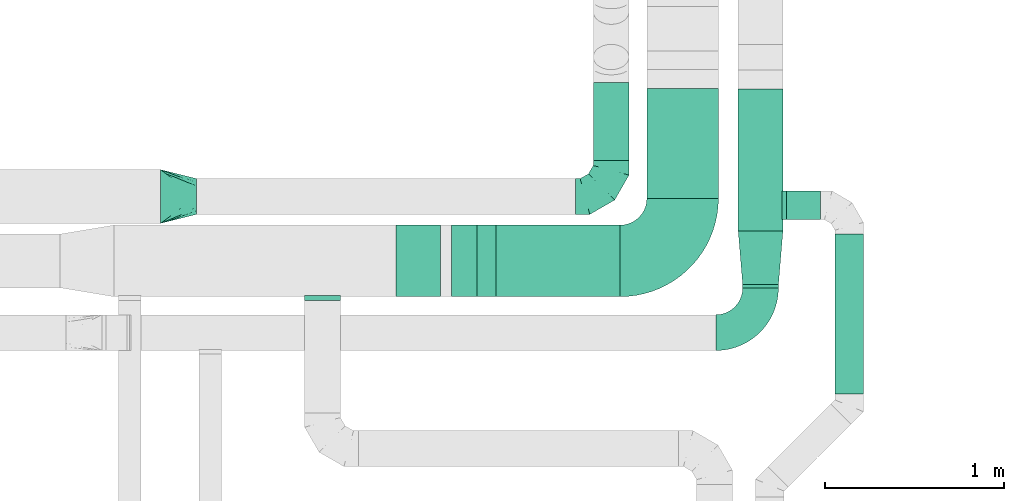
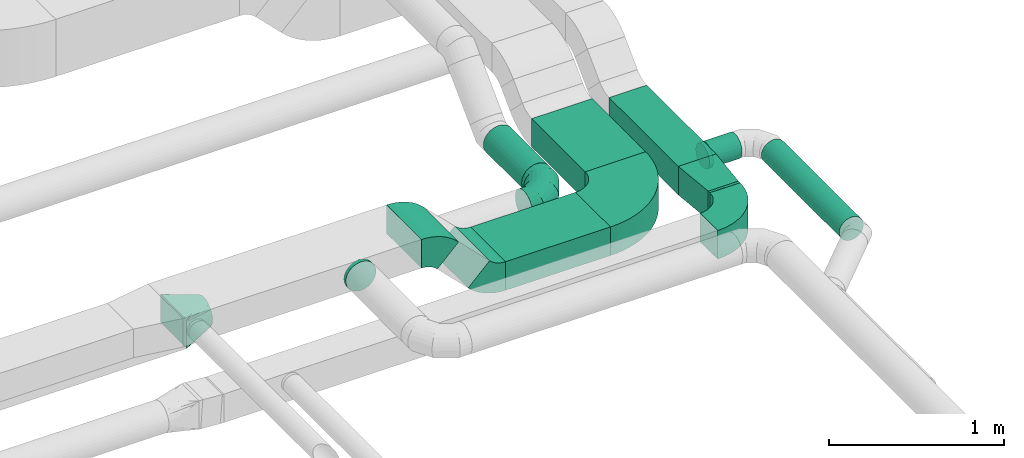
# One storey, part 27 of 60: 9 flow fittings, 7 flow segments.
"""IFC2X3 building model written with IfcOpenShell, lengths in millimetres."""

import ifcopenshell
import ifcopenshell.guid

model = None  # the IFC model being written
_history = None  # IfcOwnerHistory: only IFC2X3 demands one
_inside = {}  # id of a spatial element -> (the spatial element, [elements in it])
_under = {}  # id of a project, library or spatial element -> (it, [spatial elements below it])
_declared = {}  # id of a project -> (the project, [libraries it declares])
_typed = {}  # id of a type object -> (the type object, [elements of that type])
_made_of = {}  # id of a material, layer set ... -> (it, [elements and type objects made of it])


def new_model(schema):
    """Start an empty IFC model of exactly this schema.

    Asked for "IFC4X3", IfcOpenShell would pick the latest addendum, in which some entities
    have other attributes; the version numbers below select the first issue.
    IFC2X3 requires an IfcOwnerHistory on every rooted entity: one is made here for all.
    """
    global model, _history
    if schema == "IFC4X3":
        model = ifcopenshell.file(schema_version=(4, 3, 0, 0))
    else:
        model = ifcopenshell.file(schema=schema)
    _inside.clear()
    _under.clear()
    _declared.clear()
    _typed.clear()
    _made_of.clear()
    _history = None
    if model.schema == "IFC2X3":
        org = make("IfcOrganization", Name="unknown")
        user = make(
            "IfcPersonAndOrganization",
            ThePerson=make("IfcPerson", FamilyName="unknown"),
            TheOrganization=org,
        )
        app = make(
            "IfcApplication",
            ApplicationDeveloper=org,
            Version="unknown",
            ApplicationFullName="unknown",
            ApplicationIdentifier="unknown",
        )
        _history = make(
            "IfcOwnerHistory",
            OwningUser=user,
            OwningApplication=app,
            ChangeAction="ADDED",
            CreationDate=0,
        )
    return model


def make(cls, **values):
    """One entity of the class cls with the attributes given. An attribute that is None is left unset."""
    return model.create_entity(
        cls, **{name: value for name, value in values.items() if value is not None}
    )


def entity(cls, *values):
    """Any entity or typed value of the class cls, its attributes in the order of the schema. None: left unset."""
    e = model.create_entity(cls)
    for i, value in enumerate(values):
        if value is not None:
            e[i] = value
    return e


def rooted(cls, **values):
    """An entity with a GlobalId (a new one), such as an element, a storey or a relation."""
    return make(cls, GlobalId=ifcopenshell.guid.new(), OwnerHistory=_history, **values)


def si_unit(unit_type, name, prefix=None):
    """IfcSIUnit, for example si_unit("LENGTHUNIT", "METRE", prefix="MILLI")."""
    return make("IfcSIUnit", UnitType=unit_type, Prefix=prefix, Name=name)


def converted_unit(unit_type, name, factor, base, dimensions=None, offset=None):
    """IfcConversionBasedUnit, such as the inch: factor (a typed value) times the base unit."""
    return make(
        "IfcConversionBasedUnit"
        if offset is None
        else "IfcConversionBasedUnitWithOffset",
        ConversionOffset=offset,
        Dimensions=None
        if dimensions is None
        else entity("IfcDimensionalExponents", *dimensions),
        UnitType=unit_type,
        Name=name,
        ConversionFactor=make(
            "IfcMeasureWithUnit", ValueComponent=factor, UnitComponent=base
        ),
    )


def derived_unit(unit_type, elements):
    """IfcDerivedUnit: a product of units, each with its exponent."""
    return make(
        "IfcDerivedUnit",
        Elements=[
            make("IfcDerivedUnitElement", Unit=unit, Exponent=power)
            for unit, power in elements
        ],
        UnitType=unit_type,
    )


def assignment(units):
    """IfcUnitAssignment: the units of a project."""
    return None if units is None else make("IfcUnitAssignment", Units=units)


def point(xyz):
    """IfcCartesianPoint."""
    return None if xyz is None else make("IfcCartesianPoint", Coordinates=xyz)


def direction(xyz):
    """IfcDirection."""
    return None if xyz is None else make("IfcDirection", DirectionRatios=xyz)


def frame(location, z_axis=None, x_axis=None):
    """IfcAxis2Placement3D, a coordinate frame: its origin and axes. An axis left out is left unset."""
    return make(
        "IfcAxis2Placement3D",
        Location=point(location),
        Axis=direction(z_axis),
        RefDirection=direction(x_axis),
    )


def frame_2d(location, x_axis=None):
    """IfcAxis2Placement2D, a coordinate frame in the plane: its origin and x axis."""
    return make(
        "IfcAxis2Placement2D", Location=point(location), RefDirection=direction(x_axis)
    )


def origin():
    """The frame at (0, 0, 0) with its axes left unset."""
    return frame((0.0, 0.0, 0.0))


def origin_2d_with_axis():
    """The frame at (0, 0) in the plane with the x axis (1, 0) written out."""
    return frame_2d((0.0, 0.0), x_axis=(1.0, 0.0))


def place(relative_to, where):
    """IfcLocalPlacement: puts the frame where relative to a parent placement (None: the world)."""
    return make(
        "IfcLocalPlacement", PlacementRelTo=relative_to, RelativePlacement=where
    )


def context(
    kind, dimensions, precision=None, world=None, true_north=None, identifier=None
):
    """IfcGeometricRepresentationContext, for example the 3D "Model" context."""
    return make(
        "IfcGeometricRepresentationContext",
        ContextIdentifier=identifier,
        ContextType=kind,
        CoordinateSpaceDimension=dimensions,
        Precision=precision,
        WorldCoordinateSystem=world,
        TrueNorth=true_north,
    )


def subcontext(parent, identifier, kind, view, scale=None):
    """IfcGeometricRepresentationSubContext, for example "Body" below "Model"."""
    return make(
        "IfcGeometricRepresentationSubContext",
        ContextIdentifier=identifier,
        ContextType=kind,
        ParentContext=parent,
        TargetScale=scale,
        TargetView=view,
    )


def project(units=None, contexts=None):
    """IfcProject with its units and contexts."""
    return rooted(
        "IfcProject",
        Name="project",
        RepresentationContexts=contexts,
        UnitsInContext=assignment(units),
    )


def spatial(cls, under=None, at=None, **own):
    """A site, building, storey or space (cls), placed at a placement, below another one or the project."""
    s = rooted(cls, ObjectPlacement=at, **own)
    if under is not None:
        _under.setdefault(under.id(), (under, []))[1].append(s)
    return s


def polyline(points):
    """IfcPolyline through the points."""
    return make("IfcPolyline", Points=[point(p) for p in points])


def circle_curve(where, radius):
    """IfcCircle in the frame where."""
    return make("IfcCircle", Position=where, Radius=radius)


def parameter(value):
    """IfcParameterValue: where a trimmed curve begins or ends, as a parameter of its basis curve."""
    return model.create_entity("IfcParameterValue", value)


def trimmed(basis, trim1, trim2, sense, master):
    """IfcTrimmedCurve: the piece of a basis curve between two trims."""
    return make(
        "IfcTrimmedCurve",
        BasisCurve=basis,
        Trim1=trim1,
        Trim2=trim2,
        SenseAgreement=sense,
        MasterRepresentation=master,
    )


def segment(curve, same_sense, transition):
    """IfcCompositeCurveSegment."""
    return make(
        "IfcCompositeCurveSegment",
        Transition=transition,
        SameSense=same_sense,
        ParentCurve=curve,
    )


def composite_curve(segments, self_intersect=None):
    """IfcCompositeCurve: segments joined end to end."""
    return make("IfcCompositeCurve", Segments=segments, SelfIntersect=self_intersect)


def profile(cls, at=None, kind="AREA", **sizes):
    """A parametric profile (cls). Its sizes go by their IFC names, for example OverallWidth=200.0."""
    return make(cls, ProfileType=kind, Position=at, **sizes)


def rectangle(**sizes):
    """IfcRectangleProfileDef."""
    return profile("IfcRectangleProfileDef", **sizes)


def circle(**sizes):
    """IfcCircleProfileDef."""
    return profile("IfcCircleProfileDef", **sizes)


def outline(outer, holes=None, kind="AREA"):
    """IfcArbitraryClosedProfileDef: a profile drawn as a closed curve; with holes, ...WithVoids."""
    if holes is None:
        return make("IfcArbitraryClosedProfileDef", ProfileType=kind, OuterCurve=outer)
    return make(
        "IfcArbitraryProfileDefWithVoids",
        ProfileType=kind,
        OuterCurve=outer,
        InnerCurves=holes,
    )


def extrude(swept, where, along, depth):
    """IfcExtrudedAreaSolid: the profile swept, set in the frame where, extruded along a direction by depth."""
    return make(
        "IfcExtrudedAreaSolid",
        SweptArea=swept,
        Position=where,
        ExtrudedDirection=direction(along),
        Depth=depth,
    )


def faces_of(points, faces, orient=None, outer=None):
    """IfcFace entities. A face is a list of loops; a loop is a list of indices into points, from 0.

    orient and outer hold one flag for each loop. By default every Orientation is true, the
    first loop of a face is its IfcFaceOuterBound and the others are IfcFaceBound.
    """
    made = []
    for i, loops in enumerate(faces):
        bounds = []
        for j, loop in enumerate(loops):
            is_outer = j == 0 if outer is None else outer[i][j]
            bounds.append(
                make(
                    "IfcFaceOuterBound" if is_outer else "IfcFaceBound",
                    Bound=make("IfcPolyLoop", Polygon=[points[k] for k in loop]),
                    Orientation=True if orient is None else orient[i][j],
                )
            )
        made.append(make("IfcFace", Bounds=bounds))
    return made


def faceted_brep(points, faces, orient=None, outer=None, voids=None):
    """IfcFacetedBrep: a solid bounded by flat faces; with voids (closed shells), ...WithVoids."""
    shared = [point(p) for p in points]
    hull = make("IfcClosedShell", CfsFaces=faces_of(shared, faces, orient, outer))
    if voids is None:
        return make("IfcFacetedBrep", Outer=hull)
    return make(
        "IfcFacetedBrepWithVoids",
        Outer=hull,
        Voids=[
            make(cls, CfsFaces=faces_of(shared, fs, o, b)) for cls, fs, o, b in voids
        ],
    )


def shape(context_of_items, identifier, shape_type, items):
    """IfcShapeRepresentation: the items that make up one representation, for example the "Body"."""
    return make(
        "IfcShapeRepresentation",
        ContextOfItems=context_of_items,
        RepresentationIdentifier=identifier,
        RepresentationType=shape_type,
        Items=items,
    )


def source(mapping_origin, context_of_items, identifier, shape_type, items):
    """IfcRepresentationMap: a shape defined once, which mapped items show again and again."""
    return make(
        "IfcRepresentationMap",
        MappingOrigin=mapping_origin,
        MappedRepresentation=shape(context_of_items, identifier, shape_type, items),
    )


def transform(
    local_origin,
    x_axis=None,
    y_axis=None,
    z_axis=None,
    scale=None,
    scale2=None,
    scale3=None,
    uniform=True,
):
    """IfcCartesianTransformationOperator3D, or its non-uniform kind. x_axis, y_axis, z_axis: its Axis1, 2, 3."""
    if uniform:
        return make(
            "IfcCartesianTransformationOperator3D",
            Axis1=direction(x_axis),
            Axis2=direction(y_axis),
            LocalOrigin=point(local_origin),
            Scale=scale,
            Axis3=direction(z_axis),
        )
    return make(
        "IfcCartesianTransformationOperator3DnonUniform",
        Axis1=direction(x_axis),
        Axis2=direction(y_axis),
        LocalOrigin=point(local_origin),
        Scale=scale,
        Axis3=direction(z_axis),
        Scale2=scale2,
        Scale3=scale3,
    )


def mapped(mapping_source, mapping_target):
    """IfcMappedItem: shows the shape of a source again, moved by a transform."""
    return make(
        "IfcMappedItem", MappingSource=mapping_source, MappingTarget=mapping_target
    )


def material(Name=None, Category=None):
    """IfcMaterial."""
    return make("IfcMaterial", Name=Name, Category=Category)


def made_of(thing, what):
    """Note that an element or type object is made of a material, layer set ...; save() writes the relation."""
    if what is not None:
        _made_of.setdefault(what.id(), (what, []))[1].append(thing)
    return thing


def type_object(cls, material=None, **own):
    """A type object (cls), such as IfcWallType, which elements share."""
    return made_of(rooted(cls, **own), material)


def type_shapes(of_type, sources):
    """Give a type object the sources (RepresentationMaps) that its elements show as mapped items."""
    of_type.RepresentationMaps = sources


def element(
    cls,
    number,
    at=None,
    inside=None,
    cuts=None,
    type_object=None,
    material=None,
    context=None,
    identifier="Body",
    shape_type=None,
    held_by="IfcProductDefinitionShape",
    body=None,
    shapes=None,
    **own,
):
    """One element of the class cls, such as IfcWall. Its Tag is "e" and its number.

    at: its placement. inside: the storey or other place that contains it. cuts: it is an
    opening in that element (IfcRelVoidsElement). A single representation is given by context,
    identifier, shape_type and body (its items); several are given by shapes. held_by: the class
    of the entity that holds the representations. save() writes the other relations.
    """
    e = rooted(cls, Tag="e%d" % number, ObjectPlacement=at, **own)
    if body is not None:
        shapes = [shape(context, identifier, shape_type, body)]
    if shapes is not None:
        e.Representation = make(held_by, Representations=shapes)
    if inside is not None:
        _inside.setdefault(inside.id(), (inside, []))[1].append(e)
    if cuts is not None:
        rooted(
            "IfcRelVoidsElement", RelatingBuildingElement=cuts, RelatedOpeningElement=e
        )
    if type_object is not None:
        _typed.setdefault(type_object.id(), (type_object, []))[1].append(e)
    return made_of(e, material)


def aggregate(whole, parts):
    """IfcRelAggregates: a whole, such as a stair, and the parts it consists of."""
    return rooted("IfcRelAggregates", RelatingObject=whole, RelatedObjects=parts)


def save(model, path):
    """Write the relations noted so far, then the file.

    IfcRelAggregates (storeys below a building ...), IfcRelContainedInSpatialStructure (elements
    in a storey), IfcRelDefinesByType, IfcRelAssociatesMaterial and IfcRelDeclares: one each for
    every whole, place, type object, material and project.
    """
    for whole, parts in _under.values():
        aggregate(whole, parts)
    for where, things in _inside.values():
        rooted(
            "IfcRelContainedInSpatialStructure",
            RelatedElements=things,
            RelatingStructure=where,
        )
    for kind, things in _typed.values():
        rooted("IfcRelDefinesByType", RelatedObjects=things, RelatingType=kind)
    for what, things in _made_of.values():
        rooted("IfcRelAssociatesMaterial", RelatedObjects=things, RelatingMaterial=what)
    for by, libraries in _declared.values():
        rooted("IfcRelDeclares", RelatingContext=by, RelatedDefinitions=libraries)
    model.write(path)


model = new_model("IFC2X3")

# Units and contexts
model_context = context("Model", 3, precision=0.01, world=origin(), true_north=direction((6.12303176911189e-17, 1.0)))
body_context = subcontext(model_context, "Body", "Model", "MODEL_VIEW")
ifc_project = project(units=[si_unit("LENGTHUNIT", "METRE", prefix="MILLI"), si_unit("AREAUNIT", "SQUARE_METRE"), si_unit("VOLUMEUNIT", "CUBIC_METRE"), converted_unit("PLANEANGLEUNIT", "DEGREE", entity("IfcRatioMeasure", 0.0174532925199433), si_unit("PLANEANGLEUNIT", "RADIAN"), dimensions=[0, 0, 0, 0, 0, 0, 0]), si_unit("MASSUNIT", "GRAM", prefix="KILO"), derived_unit("MASSDENSITYUNIT", [(si_unit("MASSUNIT", "GRAM", prefix="KILO"), 1), (si_unit("LENGTHUNIT", "METRE"), -3)]), derived_unit("MOMENTOFINERTIAUNIT", [(si_unit("LENGTHUNIT", "METRE"), 4)]), si_unit("TIMEUNIT", "SECOND"), si_unit("FREQUENCYUNIT", "HERTZ"), si_unit("THERMODYNAMICTEMPERATUREUNIT", "DEGREE_CELSIUS"), derived_unit("THERMALTRANSMITTANCEUNIT", [(si_unit("MASSUNIT", "GRAM", prefix="KILO"), 1), (si_unit("THERMODYNAMICTEMPERATUREUNIT", "KELVIN"), -1), (si_unit("TIMEUNIT", "SECOND"), -3)]), derived_unit("VOLUMETRICFLOWRATEUNIT", [(si_unit("LENGTHUNIT", "METRE"), 3), (si_unit("TIMEUNIT", "SECOND"), -1)]), derived_unit("MASSFLOWRATEUNIT", [(si_unit("MASSUNIT", "GRAM", prefix="KILO"), 1), (si_unit("TIMEUNIT", "SECOND"), -1)]), derived_unit("ROTATIONALFREQUENCYUNIT", [(si_unit("TIMEUNIT", "SECOND"), -1)]), si_unit("ELECTRICCURRENTUNIT", "AMPERE"), si_unit("ELECTRICVOLTAGEUNIT", "VOLT"), si_unit("POWERUNIT", "WATT"), si_unit("FORCEUNIT", "NEWTON", prefix="KILO"), si_unit("ILLUMINANCEUNIT", "LUX"), si_unit("LUMINOUSFLUXUNIT", "LUMEN"), si_unit("LUMINOUSINTENSITYUNIT", "CANDELA"), derived_unit("USERDEFINED", [(si_unit("MASSUNIT", "GRAM", prefix="KILO"), -1), (si_unit("LENGTHUNIT", "METRE"), -2), (si_unit("TIMEUNIT", "SECOND"), 3), (si_unit("LUMINOUSFLUXUNIT", "LUMEN"), 1)]), derived_unit("LINEARVELOCITYUNIT", [(si_unit("LENGTHUNIT", "METRE"), 1), (si_unit("TIMEUNIT", "SECOND"), -1)]), si_unit("PRESSUREUNIT", "PASCAL"), derived_unit("USERDEFINED", [(si_unit("LENGTHUNIT", "METRE"), -2), (si_unit("MASSUNIT", "GRAM", prefix="KILO"), 1), (si_unit("TIMEUNIT", "SECOND"), -2)]), derived_unit("LINEARFORCEUNIT", [(si_unit("MASSUNIT", "GRAM", prefix="KILO"), 1), (si_unit("LENGTHUNIT", "METRE"), 1), (si_unit("TIMEUNIT", "SECOND"), -2), (si_unit("LENGTHUNIT", "METRE"), -1)]), derived_unit("PLANARFORCEUNIT", [(si_unit("MASSUNIT", "GRAM", prefix="KILO"), 1), (si_unit("LENGTHUNIT", "METRE"), 1), (si_unit("TIMEUNIT", "SECOND"), -2), (si_unit("LENGTHUNIT", "METRE"), -2)])], contexts=[model_context])

# Site, building, storey
site_placement = place(None, origin())
site = spatial("IfcSite", under=ifc_project, at=site_placement, CompositionType="ELEMENT")
building_placement = place(site_placement, origin())
building = spatial("IfcBuilding", under=site, at=building_placement, CompositionType="ELEMENT")
storey_placement = place(building_placement, frame((0.0, 0.0, 19800.0)))
storey = spatial("IfcBuildingStorey", under=building, at=storey_placement, CompositionType="ELEMENT", Elevation=19800.0)

# Flow segments
duct_segment_type_1 = type_object("IfcDuctSegmentType", PredefinedType="NOTDEFINED")
flow_segment_1_placement = place(storey_placement, frame((46370.09, 5575.34, 3150.0)))
element("IfcFlowSegment", 1, at=flow_segment_1_placement, inside=storey, type_object=duct_segment_type_1, context=body_context, shape_type="SweptSolid", body=[
    extrude(rectangle(XDim=613.446609406731, YDim=400.000000000004, at=origin_2d_with_axis()), frame((200.0, 306.72, 0.0), z_axis=(0.0, 0.0, 1.0), x_axis=(0.0, -1.0, 0.0)), (0.0, 0.0, 1.0), 199.999999999998),
])
flow_segment_2_placement = place(storey_placement, frame((45525.65, 5025.34, 3150.0)))
element("IfcFlowSegment", 2, at=flow_segment_2_placement, inside=storey, type_object=duct_segment_type_1, context=body_context, shape_type="SweptSolid", body=[
    extrude(rectangle(XDim=694.446609406683, YDim=400.0, at=origin_2d_with_axis()), frame((347.22, 200.0, 0.0), z_axis=(0.0, 0.0, 1.0), x_axis=(-1.0, 0.0, 0.0)), (0.0, 0.0, 1.0), 199.999999999998),
])
flow_segment_3_placement = place(storey_placement, frame((46880.37, 5392.65, 3119.89)))
element("IfcFlowSegment", 3, at=flow_segment_3_placement, inside=storey, type_object=duct_segment_type_1, context=body_context, shape_type="SweptSolid", body=[
    extrude(rectangle(XDim=793.4466094067, YDim=250.000000000004, at=origin_2d_with_axis()), frame((125.0, 396.72, 0.0), z_axis=(0.0, 0.0, 1.0), x_axis=(0.0, -1.0, 0.0)), (0.0, 0.0, 1.0), 199.999999999998),
])
flow_segment_4_placement = place(storey_placement, frame((46905.37, 5074.52, 3119.89)))
element("IfcFlowSegment", 4, at=flow_segment_4_placement, inside=storey, type_object=duct_segment_type_1, context=body_context, shape_type="SweptSolid", body=[
    extrude(rectangle(XDim=18.1249999999547, YDim=199.999999999998, at=origin_2d_with_axis()), frame((100.0, 9.06, 0.0), z_axis=(0.0, 0.0, 1.0), x_axis=(0.0, -1.0, 0.0)), (0.0, 0.0, 1.0), 199.999999999998),
])
duct_segment_type_2 = type_object("IfcDuctSegmentType", PredefinedType="NOTDEFINED")
flow_segment_5_placement = place(storey_placement, frame((46068.81, 5785.05, 3148.4)))
element("IfcFlowSegment", 5, at=flow_segment_5_placement, inside=storey, type_object=duct_segment_type_2, context=body_context, shape_type="SweptSolid", body=[
    extrude(circle(Radius=100.0, at=origin_2d_with_axis()), frame((101.6, 0.0, 101.6), z_axis=(0.0, 1.0, 0.0), x_axis=(1.0, 0.0, 0.0)), (0.0, 0.0, 1.0), 438.157287525335),
])
flow_segment_6_placement = place(storey_placement, frame((47150.37, 5454.35, 3138.29)))
element("IfcFlowSegment", 6, at=flow_segment_6_placement, inside=storey, type_object=duct_segment_type_2, context=body_context, shape_type="SweptSolid", body=[
    extrude(circle(Radius=80.0, at=origin_2d_with_axis()), frame((0.0, 81.6, 81.6), z_axis=(1.0, 0.0, 0.0), x_axis=(0.0, -1.0, 0.0)), (0.0, 0.0, 1.0), 190.000000000043),
])
flow_segment_7_placement = place(storey_placement, frame((47418.78, 4482.22, 3138.29)))
element("IfcFlowSegment", 7, at=flow_segment_7_placement, inside=storey, type_object=duct_segment_type_2, context=body_context, shape_type="SweptSolid", body=[
    extrude(circle(Radius=80.0, at=origin_2d_with_axis()), frame((81.6, 0.0, 81.6), z_axis=(0.0, 1.0, 0.0), x_axis=(-1.0, 0.0, 0.0)), (0.0, 0.0, 1.0), 893.725830020254),
])

# Flow fittings
ifc_material = material()
duct_fitting_type_1 = type_object("IfcDuctFittingType", PredefinedType="NOTDEFINED", material=ifc_material)
shared_shape_1 = source(origin(), body_context, "Body", "SweptSolid", [
    extrude(outline(polyline([(-159.86, -112.11), (141.18, -112.11), (157.79, 87.2), (-139.1, 137.03), (-159.86, -112.11)])), frame((150.0, 0.0, -100.0), z_axis=(0.0, 0.0, 1.0), x_axis=(0.99654575824488, 0.0830454798537381, 0.0)), (0.0, 0.0, 1.0), 200.0),
])
type_shapes(duct_fitting_type_1, [shared_shape_1])
flow_fitting_1_placement = place(storey_placement, frame((47005.37, 5392.65, 3220.0), z_axis=(0.0, 0.0, 1.0), x_axis=(0.0, -1.0, 0.0)))
element("IfcFlowFitting", 8, at=flow_fitting_1_placement, inside=storey, type_object=duct_fitting_type_1, material=ifc_material, context=body_context, shape_type="MappedRepresentation", body=[
    mapped(shared_shape_1, transform((0.0, 0.0, 0.0), scale=1.0)),
])
duct_fitting_type_2 = type_object("IfcDuctFittingType", PredefinedType="NOTDEFINED", material=ifc_material)
shared_shape_2 = source(origin(), body_context, "Body", "Brep", [
    faceted_brep([(-200.0, 0.0, -100.0), (-200.0, -25.88, -96.59), (-200.0, -50.0, -86.6), (-200.0, -70.71, -70.71), (-200.0, -86.6, -50.0), (-200.0, -96.59, -25.88), (-200.0, -100.0, 0.0), (-200.0, -96.59, 25.88), (-200.0, -86.6, 50.0), (-200.0, -70.71, 70.71), (-200.0, -50.0, 86.6), (-200.0, -25.88, 96.59), (-200.0, 0.0, 100.0), (-200.0, 25.88, 96.59), (-200.0, 50.0, 86.6), (-200.0, 70.71, 70.71), (-200.0, 86.6, 50.0), (-200.0, 96.59, 25.88), (-200.0, 100.0, 0.0), (-200.0, 96.59, -25.88), (-200.0, 86.6, -50.0), (-200.0, 70.71, -70.71), (-200.0, 50.0, -86.6), (-200.0, 25.88, -96.59), (-153.35, 25.88, 96.59), (-159.81, 50.0, 86.6), (-146.41, 0.0, 100.0), (-165.36, 70.71, 70.71), (-172.29, 96.59, 25.88), (-173.21, 100.0, 0.0), (-169.62, 86.6, 50.0), (-169.62, 86.6, -50.0), (-165.36, 70.71, -70.71), (-172.29, 96.59, -25.88), (-153.35, 25.88, -96.59), (-146.41, 0.0, -100.0), (-159.81, 50.0, -86.6), (-139.48, -25.88, -96.59), (-133.01, -50.0, -86.6), (-127.46, -70.71, -70.71), (-123.21, -86.6, -50.0), (-120.53, -96.59, -25.88), (-119.62, -100.0, 0.0), (-120.53, -96.59, 25.88), (-123.21, -86.6, 50.0), (-127.46, -70.71, 70.71), (-133.01, -50.0, 86.6), (-139.48, -25.88, 96.59), (-72.54, 72.54, 96.59), (-90.19, 90.19, 86.6), (-53.59, 53.59, 100.0), (-105.35, 105.35, 70.71), (-116.99, 116.99, 50.0), (-124.3, 124.3, 25.88), (-126.79, 126.79, 0.0), (-124.3, 124.3, -25.88), (-116.99, 116.99, -50.0), (-105.35, 105.35, -70.71), (-72.54, 72.54, -96.59), (-53.59, 53.59, -100.0), (-90.19, 90.19, -86.6), (-34.64, 34.64, -96.59), (-16.99, 16.99, -86.6), (-1.83, 1.83, -70.71), (9.81, -9.81, -50.0), (17.12, -17.12, -25.88), (19.62, -19.62, 0.0), (17.12, -17.12, 25.88), (9.81, -9.81, 50.0), (-1.83, 1.83, 70.71), (-16.99, 16.99, 86.6), (-34.64, 34.64, 96.59), (-25.88, 153.35, 96.59), (-50.0, 159.81, 86.6), (0.0, 146.41, 100.0), (-70.71, 165.36, 70.71), (-86.6, 169.62, 50.0), (-96.59, 172.29, 25.88), (-100.0, 173.21, 0.0), (-96.59, 172.29, -25.88), (-86.6, 169.62, -50.0), (-70.71, 165.36, -70.71), (-25.88, 153.35, -96.59), (0.0, 146.41, -100.0), (-50.0, 159.81, -86.6), (25.88, 139.48, -96.59), (50.0, 133.01, -86.6), (70.71, 127.46, -70.71), (86.6, 123.21, -50.0), (96.59, 120.53, -25.88), (100.0, 119.62, 0.0), (96.59, 120.53, 25.88), (86.6, 123.21, 50.0), (70.71, 127.46, 70.71), (50.0, 133.01, 86.6), (25.88, 139.48, 96.59), (-25.88, 200.0, -96.59), (-50.0, 200.0, -86.6), (-70.71, 200.0, -70.71), (-86.6, 200.0, -50.0), (-96.59, 200.0, -25.88), (-100.0, 200.0, 0.0), (-96.59, 200.0, 25.88), (-86.6, 200.0, 50.0), (-70.71, 200.0, 70.71), (-50.0, 200.0, 86.6), (-25.88, 200.0, 96.59), (0.0, 200.0, 100.0), (25.88, 200.0, 96.59), (50.0, 200.0, 86.6), (70.71, 200.0, 70.71), (86.6, 200.0, 50.0), (96.59, 200.0, 25.88), (100.0, 200.0, 0.0), (96.59, 200.0, -25.88), (86.6, 200.0, -50.0), (70.71, 200.0, -70.71), (50.0, 200.0, -86.6), (25.88, 200.0, -96.59), (0.0, 200.0, -100.0)], [[[0, 1, 2, 3, 4, 5, 6, 7, 8, 9, 10, 11, 12, 13, 14, 15, 16, 17, 18, 19, 20, 21, 22, 23]], [[24, 25, 14, 13]], [[26, 24, 13, 12]], [[14, 25, 27, 15]], [[28, 29, 18, 17]], [[30, 28, 17, 16]], [[15, 27, 30, 16]], [[20, 31, 32, 21]], [[33, 31, 20, 19]], [[18, 29, 33, 19]], [[34, 35, 0, 23]], [[36, 34, 23, 22]], [[32, 36, 22, 21]], [[1, 0, 35, 37]], [[2, 1, 37, 38]], [[38, 39, 3, 2]], [[5, 4, 40, 41]], [[6, 5, 41, 42]], [[39, 40, 4, 3]], [[6, 42, 43, 7]], [[7, 43, 44, 8]], [[8, 44, 45, 9]], [[9, 45, 46, 10]], [[10, 46, 47, 11]], [[26, 12, 11, 47]], [[48, 49, 25, 24]], [[50, 48, 24, 26]], [[27, 25, 49, 51]], [[52, 53, 28, 30]], [[51, 52, 30, 27]], [[29, 28, 53, 54]], [[55, 56, 31, 33]], [[54, 55, 33, 29]], [[32, 31, 56, 57]], [[58, 59, 35, 34]], [[60, 58, 34, 36]], [[57, 60, 36, 32]], [[37, 35, 59, 61]], [[38, 37, 61, 62]], [[39, 38, 62, 63]], [[41, 40, 64, 65]], [[42, 41, 65, 66]], [[63, 64, 40, 39]], [[43, 42, 66, 67]], [[44, 43, 67, 68]], [[68, 69, 45, 44]], [[46, 45, 69, 70]], [[47, 46, 70, 71]], [[26, 47, 71, 50]], [[72, 73, 49, 48]], [[74, 72, 48, 50]], [[51, 49, 73, 75]], [[76, 77, 53, 52]], [[75, 76, 52, 51]], [[54, 53, 77, 78]], [[79, 80, 56, 55]], [[78, 79, 55, 54]], [[57, 56, 80, 81]], [[82, 83, 59, 58]], [[84, 82, 58, 60]], [[81, 84, 60, 57]], [[61, 59, 83, 85]], [[62, 61, 85, 86]], [[63, 62, 86, 87]], [[65, 64, 88, 89]], [[66, 65, 89, 90]], [[87, 88, 64, 63]], [[67, 66, 90, 91]], [[68, 67, 91, 92]], [[92, 93, 69, 68]], [[70, 69, 93, 94]], [[71, 70, 94, 95]], [[50, 71, 95, 74]], [[96, 97, 98, 99, 100, 101, 102, 103, 104, 105, 106, 107, 108, 109, 110, 111, 112, 113, 114, 115, 116, 117, 118, 119]], [[72, 74, 107, 106]], [[73, 72, 106, 105]], [[75, 73, 105, 104]], [[102, 101, 78, 77]], [[103, 102, 77, 76]], [[75, 104, 103, 76]], [[78, 101, 100, 79]], [[79, 100, 99, 80]], [[80, 99, 98, 81]], [[84, 97, 96, 82]], [[82, 96, 119, 83]], [[84, 81, 98, 97]], [[118, 117, 86, 85]], [[119, 118, 85, 83]], [[116, 87, 86, 117]], [[88, 115, 114, 89]], [[89, 114, 113, 90]], [[115, 88, 87, 116]], [[91, 90, 113, 112]], [[92, 91, 112, 111]], [[111, 110, 93, 92]], [[95, 94, 109, 108]], [[74, 95, 108, 107]], [[110, 109, 94, 93]]]),
])
type_shapes(duct_fitting_type_2, [shared_shape_2])
flow_fitting_2_placement = place(storey_placement, frame((46170.4, 5585.05, 3250.0)))
element("IfcFlowFitting", 9, at=flow_fitting_2_placement, inside=storey, type_object=duct_fitting_type_2, material=ifc_material, context=body_context, shape_type="MappedRepresentation", body=[
    mapped(shared_shape_2, transform((0.0, 0.0, 0.0), scale=1.0)),
])
duct_fitting_type_3 = type_object("IfcDuctFittingType", PredefinedType="NOTDEFINED", material=ifc_material)
shared_shape_3 = source(origin(), body_context, "Body", "Brep", [
    faceted_brep([(20.0, 0.0, -80.0), (20.0, 20.71, -77.27), (20.0, 40.0, -69.28), (20.0, 56.57, -56.57), (20.0, 69.28, -40.0), (20.0, 77.27, -20.71), (20.0, 80.0, 0.0), (20.0, 77.27, 20.71), (20.0, 69.28, 40.0), (20.0, 56.57, 56.57), (20.0, 40.0, 69.28), (20.0, 20.71, 77.27), (20.0, 0.0, 80.0), (20.0, -20.71, 77.27), (20.0, -40.0, 69.28), (20.0, -56.57, 56.57), (20.0, -69.28, 40.0), (20.0, -77.27, 20.71), (20.0, -80.0, 0.0), (20.0, -77.27, -20.71), (20.0, -69.28, -40.0), (20.0, -56.57, -56.57), (20.0, -40.0, -69.28), (20.0, -20.71, -77.27), (0.0, 0.0, 80.0), (-6.1, 0.0, 80.0), (-6.1, -20.71, 77.27), (0.0, -20.71, 77.27), (-6.1, -40.0, 69.28), (0.0, -40.0, 69.28), (0.0, -56.57, 56.57), (-6.1, -56.57, 56.57), (0.0, -69.28, 40.0), (-6.1, -69.28, 40.0), (-6.1, -77.27, 20.71), (0.0, -77.27, 20.71), (-6.1, -80.0, 0.0), (0.0, -80.0, 0.0), (-6.1, -77.27, -20.71), (0.0, -77.27, -20.71), (-6.1, -69.28, -40.0), (0.0, -69.28, -40.0), (0.0, -56.57, -56.57), (-6.1, -56.57, -56.57), (0.0, -40.0, -69.28), (-6.1, -40.0, -69.28), (-6.1, -20.71, -77.27), (0.0, -20.71, -77.27), (-6.1, 0.0, -80.0), (0.0, 0.0, -80.0), (-6.1, 20.71, -77.27), (0.0, 20.71, -77.27), (-6.1, 40.0, -69.28), (0.0, 40.0, -69.28), (0.0, 56.57, -56.57), (-6.1, 56.57, -56.57), (0.0, 69.28, -40.0), (-6.1, 69.28, -40.0), (-6.1, 77.27, -20.71), (0.0, 77.27, -20.71), (-6.1, 80.0, 0.0), (0.0, 80.0, 0.0), (-6.1, 77.27, 20.71), (0.0, 77.27, 20.71), (-6.1, 69.28, 40.0), (0.0, 69.28, 40.0), (0.0, 56.57, 56.57), (-6.1, 56.57, 56.57), (0.0, 40.0, 69.28), (-6.1, 40.0, 69.28), (-6.1, 20.71, 77.27), (0.0, 20.71, 77.27)], [[[0, 1, 2, 3, 4, 5, 6, 7, 8, 9, 10, 11, 12, 13, 14, 15, 16, 17, 18, 19, 20, 21, 22, 23]], [[13, 12, 24, 25, 26, 27]], [[14, 13, 27, 26, 28, 29]], [[30, 15, 14, 29, 28, 31]], [[17, 16, 32, 33, 34, 35]], [[18, 17, 35, 34, 36, 37]], [[32, 16, 15, 30, 31, 33]], [[19, 18, 37, 36, 38, 39]], [[20, 19, 39, 38, 40, 41]], [[42, 21, 20, 41, 40, 43]], [[23, 22, 44, 45, 46, 47]], [[0, 23, 47, 46, 48, 49]], [[44, 22, 21, 42, 43, 45]], [[1, 0, 49, 48, 50, 51]], [[2, 1, 51, 50, 52, 53]], [[54, 3, 2, 53, 52, 55]], [[5, 4, 56, 57, 58, 59]], [[6, 5, 59, 58, 60, 61]], [[56, 4, 3, 54, 55, 57]], [[7, 6, 61, 60, 62, 63]], [[8, 7, 63, 62, 64, 65]], [[66, 9, 8, 65, 64, 67]], [[11, 10, 68, 69, 70, 71]], [[12, 11, 71, 70, 25, 24]], [[68, 10, 9, 66, 67, 69]], [[46, 45, 43, 40, 38, 36, 34, 33, 31, 28, 26, 25, 70, 69, 67, 64, 62, 60, 58, 57, 55, 52, 50, 48]]]),
])
type_shapes(duct_fitting_type_3, [shared_shape_3])
flow_fitting_3_placement = place(storey_placement, frame((47130.37, 5535.94, 3219.89), z_axis=(0.0, 0.0, -1.0), x_axis=(1.0, 0.0, 0.0)))
element("IfcFlowFitting", 10, at=flow_fitting_3_placement, inside=storey, type_object=duct_fitting_type_3, material=ifc_material, context=body_context, shape_type="MappedRepresentation", body=[
    mapped(shared_shape_3, transform((0.0, 0.0, 0.0), scale=1.0)),
])
duct_fitting_type_4 = type_object("IfcDuctFittingType", PredefinedType="NOTDEFINED", material=ifc_material)
shared_shape_4 = source(origin(), body_context, "Body", "Brep", [
    faceted_brep([(20.0, 0.0, -100.0), (20.0, 25.88, -96.59), (20.0, 50.0, -86.6), (20.0, 70.71, -70.71), (20.0, 86.6, -50.0), (20.0, 96.59, -25.88), (20.0, 100.0, 0.0), (20.0, 96.59, 25.88), (20.0, 86.6, 50.0), (20.0, 70.71, 70.71), (20.0, 50.0, 86.6), (20.0, 25.88, 96.59), (20.0, 0.0, 100.0), (20.0, -25.88, 96.59), (20.0, -50.0, 86.6), (20.0, -70.71, 70.71), (20.0, -86.6, 50.0), (20.0, -96.59, 25.88), (20.0, -100.0, 0.0), (20.0, -96.59, -25.88), (20.0, -86.6, -50.0), (20.0, -70.71, -70.71), (20.0, -50.0, -86.6), (20.0, -25.88, -96.59), (0.0, 0.0, 100.0), (-6.1, 0.0, 100.0), (-6.1, -25.88, 96.59), (0.0, -25.88, 96.59), (-6.1, -50.0, 86.6), (0.0, -50.0, 86.6), (0.0, -70.71, 70.71), (-6.1, -70.71, 70.71), (0.0, -86.6, 50.0), (-6.1, -86.6, 50.0), (-6.1, -96.59, 25.88), (0.0, -96.59, 25.88), (-6.1, -100.0, 0.0), (0.0, -100.0, 0.0), (-6.1, -96.59, -25.88), (0.0, -96.59, -25.88), (-6.1, -86.6, -50.0), (0.0, -86.6, -50.0), (0.0, -70.71, -70.71), (-6.1, -70.71, -70.71), (0.0, -50.0, -86.6), (-6.1, -50.0, -86.6), (-6.1, -25.88, -96.59), (0.0, -25.88, -96.59), (-6.1, 0.0, -100.0), (0.0, 0.0, -100.0), (-6.1, 25.88, -96.59), (0.0, 25.88, -96.59), (-6.1, 50.0, -86.6), (0.0, 50.0, -86.6), (0.0, 70.71, -70.71), (-6.1, 70.71, -70.71), (0.0, 86.6, -50.0), (-6.1, 86.6, -50.0), (-6.1, 96.59, -25.88), (0.0, 96.59, -25.88), (-6.1, 100.0, 0.0), (0.0, 100.0, 0.0), (-6.1, 96.59, 25.88), (0.0, 96.59, 25.88), (-6.1, 86.6, 50.0), (0.0, 86.6, 50.0), (0.0, 70.71, 70.71), (-6.1, 70.71, 70.71), (0.0, 50.0, 86.6), (-6.1, 50.0, 86.6), (-6.1, 25.88, 96.59), (0.0, 25.88, 96.59)], [[[0, 1, 2, 3, 4, 5, 6, 7, 8, 9, 10, 11, 12, 13, 14, 15, 16, 17, 18, 19, 20, 21, 22, 23]], [[13, 12, 24, 25, 26, 27]], [[14, 13, 27, 26, 28, 29]], [[30, 15, 14, 29, 28, 31]], [[17, 16, 32, 33, 34, 35]], [[18, 17, 35, 34, 36, 37]], [[32, 16, 15, 30, 31, 33]], [[19, 18, 37, 36, 38, 39]], [[20, 19, 39, 38, 40, 41]], [[42, 21, 20, 41, 40, 43]], [[23, 22, 44, 45, 46, 47]], [[0, 23, 47, 46, 48, 49]], [[44, 22, 21, 42, 43, 45]], [[1, 0, 49, 48, 50, 51]], [[2, 1, 51, 50, 52, 53]], [[54, 3, 2, 53, 52, 55]], [[5, 4, 56, 57, 58, 59]], [[6, 5, 59, 58, 60, 61]], [[56, 4, 3, 54, 55, 57]], [[7, 6, 61, 60, 62, 63]], [[8, 7, 63, 62, 64, 65]], [[66, 9, 8, 65, 64, 67]], [[11, 10, 68, 69, 70, 71]], [[12, 11, 71, 70, 25, 24]], [[68, 10, 9, 66, 67, 69]], [[46, 45, 43, 40, 38, 36, 34, 33, 31, 28, 26, 25, 70, 69, 67, 64, 62, 60, 58, 57, 55, 52, 50, 48]]]),
])
type_shapes(duct_fitting_type_4, [shared_shape_4])
flow_fitting_4_placement = place(storey_placement, frame((44557.83, 5025.34, 3600.0), z_axis=(0.0, 0.0, -1.0), x_axis=(0.0, -1.0, 0.0)))
element("IfcFlowFitting", 11, at=flow_fitting_4_placement, inside=storey, type_object=duct_fitting_type_4, material=ifc_material, context=body_context, shape_type="MappedRepresentation", body=[
    mapped(shared_shape_4, transform((0.0, 0.0, 0.0), scale=1.0)),
])
duct_fitting_type_5 = type_object("IfcDuctFittingType", PredefinedType="NOTDEFINED", material=ifc_material)
shared_shape_5 = source(origin(), body_context, "Body", "Brep", [
    faceted_brep([(200.0, 30.9, 95.11), (200.0, 19.08, 96.98), (200.0, 9.54, 98.49), (200.0, 4.77, 99.24), (200.0, 0.0, 100.0), (200.0, -4.77, 99.24), (200.0, -9.54, 98.49), (200.0, -19.08, 96.98), (200.0, -30.9, 95.11), (200.0, -44.84, 88.0), (200.0, -58.78, 80.9), (200.0, -69.84, 69.84), (200.0, -80.9, 58.78), (200.0, -88.0, 44.84), (200.0, -95.11, 30.9), (200.0, -96.98, 19.08), (200.0, -98.49, 9.54), (200.0, -99.24, 4.77), (200.0, -100.0, 0.0), (200.0, -99.24, -4.77), (200.0, -98.49, -9.54), (200.0, -96.98, -19.08), (200.0, -95.11, -30.9), (200.0, -88.0, -44.84), (200.0, -80.9, -58.78), (200.0, -69.84, -69.84), (200.0, -58.78, -80.9), (200.0, -44.84, -88.0), (200.0, -30.9, -95.11), (200.0, -19.08, -96.98), (200.0, -9.54, -98.49), (200.0, -4.77, -99.24), (200.0, 0.0, -100.0), (200.0, 4.77, -99.24), (200.0, 9.54, -98.49), (200.0, 19.08, -96.98), (200.0, 30.9, -95.11), (200.0, 44.84, -88.0), (200.0, 58.78, -80.9), (200.0, 69.84, -69.84), (200.0, 80.9, -58.78), (200.0, 88.0, -44.84), (200.0, 95.11, -30.9), (200.0, 96.98, -19.08), (200.0, 98.49, -9.54), (200.0, 99.24, -4.77), (200.0, 100.0, 0.0), (200.0, 99.24, 4.77), (200.0, 98.49, 9.54), (200.0, 96.98, 19.08), (200.0, 95.11, 30.9), (200.0, 88.0, 44.84), (200.0, 80.9, 58.78), (200.0, 69.84, 69.84), (200.0, 58.78, 80.9), (200.0, 44.84, 88.0), (0.0, -150.0, 100.0), (0.0, 150.0, 100.0), (0.0, 150.0, -100.0), (0.0, -150.0, -100.0), (104.11, -71.91, 100.0), (100.0, -108.15, 87.43), (26.03, -130.48, 100.0), (78.09, -91.44, 100.0), (52.06, -110.96, 100.0), (188.01, -8.99, 100.0), (176.03, -17.98, 100.0), (152.06, -35.96, 100.0), (128.09, -53.94, 100.0), (52.06, -136.99, 73.97), (78.09, -130.48, 60.96), (104.11, -123.97, 47.94), (128.09, -117.98, 35.96), (152.06, -111.99, 23.97), (176.03, -105.99, 11.99), (188.01, -103.0, 5.99), (26.03, -143.49, 86.99), (26.03, -143.49, -86.99), (52.06, -136.99, -73.97), (78.09, -130.48, -60.96), (104.11, -123.97, -47.94), (128.09, -117.98, -35.96), (152.06, -111.99, -23.97), (176.03, -105.99, -11.99), (188.01, -103.0, -5.99), (100.0, -112.43, -83.15), (52.06, -110.96, -100.0), (78.09, -91.44, -100.0), (104.11, -71.91, -100.0), (128.09, -53.94, -100.0), (152.06, -35.96, -100.0), (176.03, -17.98, -100.0), (188.01, -8.99, -100.0), (26.03, -130.48, -100.0), (26.03, 130.48, -100.0), (52.06, 110.96, -100.0), (78.09, 91.44, -100.0), (104.11, 71.91, -100.0), (128.09, 53.94, -100.0), (152.06, 35.96, -100.0), (176.03, 17.98, -100.0), (188.01, 8.99, -100.0), (100.0, 108.15, -87.43), (52.06, 136.99, -73.97), (78.09, 130.48, -60.96), (104.11, 123.97, -47.94), (128.09, 117.98, -35.96), (152.06, 111.99, -23.97), (176.03, 105.99, -11.99), (188.01, 103.0, -5.99), (26.03, 143.49, -86.99), (26.03, 143.49, 86.99), (52.06, 136.99, 73.97), (78.09, 130.48, 60.96), (104.11, 123.97, 47.94), (128.09, 117.98, 35.96), (152.06, 111.99, 23.97), (176.03, 105.99, 11.99), (188.01, 103.0, 5.99), (100.0, 112.43, 83.15), (52.06, 110.96, 100.0), (78.09, 91.44, 100.0), (104.11, 71.91, 100.0), (128.09, 53.94, 100.0), (152.06, 35.96, 100.0), (176.03, 17.98, 100.0), (188.01, 8.99, 100.0), (26.03, 130.48, 100.0)], [[[0, 1, 2, 3, 4, 5, 6, 7, 8, 9, 10, 11, 12, 13, 14, 15, 16, 17, 18, 19, 20, 21, 22, 23, 24, 25, 26, 27, 28, 29, 30, 31, 32, 33, 34, 35, 36, 37, 38, 39, 40, 41, 42, 43, 44, 45, 46, 47, 48, 49, 50, 51, 52, 53, 54, 55]], [[56, 57, 58, 59]], [[60, 9, 8]], [[56, 61, 62]], [[9, 60, 63, 64]], [[65, 66, 67, 68, 60, 8, 7, 6, 5, 4]], [[62, 61, 10]], [[13, 69, 70, 71]], [[64, 10, 9]], [[14, 71, 72, 73, 74, 75, 18, 17, 16, 15]], [[12, 76, 69]], [[71, 14, 13]], [[61, 76, 11]], [[10, 64, 62]], [[76, 12, 11]], [[10, 61, 11]], [[61, 56, 76]], [[69, 13, 12]], [[75, 74, 73, 72, 71, 70, 69, 76, 56, 59, 77, 78, 79, 80, 81, 82, 83, 84, 18]], [[80, 23, 22]], [[59, 85, 77]], [[23, 80, 79, 78]], [[84, 83, 82, 81, 80, 22, 21, 20, 19, 18]], [[77, 85, 24]], [[27, 86, 87, 88]], [[78, 24, 23]], [[28, 88, 89, 90, 91, 92, 32, 31, 30, 29]], [[26, 93, 86]], [[88, 28, 27]], [[85, 93, 25]], [[24, 78, 77]], [[93, 26, 25]], [[24, 85, 25]], [[85, 59, 93]], [[86, 27, 26]], [[92, 91, 90, 89, 88, 87, 86, 93, 59, 58, 94, 95, 96, 97, 98, 99, 100, 101, 32]], [[97, 37, 36]], [[58, 102, 94]], [[37, 97, 96, 95]], [[101, 100, 99, 98, 97, 36, 35, 34, 33, 32]], [[94, 102, 38]], [[41, 103, 104, 105]], [[95, 38, 37]], [[42, 105, 106, 107, 108, 109, 46, 45, 44, 43]], [[40, 110, 103]], [[105, 42, 41]], [[102, 110, 39]], [[38, 95, 94]], [[110, 40, 39]], [[38, 102, 39]], [[102, 58, 110]], [[103, 41, 40]], [[58, 57, 111, 112, 113, 114, 115, 116, 117, 118, 46, 109, 108, 107, 106, 105, 104, 103, 110]], [[114, 51, 50]], [[57, 119, 111]], [[51, 114, 113, 112]], [[118, 117, 116, 115, 114, 50, 49, 48, 47, 46]], [[111, 119, 52]], [[55, 120, 121, 122]], [[112, 52, 51]], [[0, 122, 123, 124, 125, 126, 4, 3, 2, 1]], [[54, 127, 120]], [[122, 0, 55]], [[119, 127, 53]], [[52, 112, 111]], [[127, 54, 53]], [[52, 119, 53]], [[119, 57, 127]], [[120, 55, 54]], [[57, 56, 62, 64, 63, 60, 68, 67, 66, 65, 4, 126, 125, 124, 123, 122, 121, 120, 127]]]),
])
type_shapes(duct_fitting_type_5, [shared_shape_5])
flow_fitting_5_placement = place(storey_placement, frame((43652.9, 5585.05, 3250.0)))
element("IfcFlowFitting", 12, at=flow_fitting_5_placement, inside=storey, type_object=duct_fitting_type_5, material=ifc_material, context=body_context, shape_type="MappedRepresentation", body=[
    mapped(shared_shape_5, transform((0.0, 0.0, 0.0), scale=1.0)),
])
duct_fitting_type_6 = type_object("IfcDuctFittingType", PredefinedType="NOTDEFINED", material=ifc_material)
shared_shape_6 = source(origin(), body_context, "Body", "SweptSolid", [
    extrude(outline(composite_curve([segment(polyline([(-375.0, -175.0), (25.0, -175.0)]), True, "CONTINUOUS"), segment(trimmed(circle_curve(frame_2d((175.0, -175.0), x_axis=(0.0, 1.0)), 150.0), [parameter(0.0)], [parameter(90.0000000000001)], True, "PARAMETER"), False, "CONTINUOUS"), segment(polyline([(175.0, -25.0), (175.0, 375.0)]), True, "CONTINUOUS"), segment(trimmed(circle_curve(frame_2d((175.0, -175.0), x_axis=(0.0, 1.0)), 550.0), [parameter(0.0)], [parameter(90.0)], True, "PARAMETER"), True, "CONTINUOUS")], self_intersect=False)), frame((-175.0, 175.0, -100.0), z_axis=(0.0, 0.0, 1.0), x_axis=(-1.0, 0.0, 0.0)), (0.0, 0.0, 1.0), 200.0),
])
type_shapes(duct_fitting_type_6, [shared_shape_6])
flow_fitting_6_placement = place(storey_placement, frame((46570.09, 5225.34, 3250.0)))
element("IfcFlowFitting", 13, at=flow_fitting_6_placement, inside=storey, type_object=duct_fitting_type_6, material=ifc_material, context=body_context, shape_type="MappedRepresentation", body=[
    mapped(shared_shape_6, transform((0.0, 0.0, 0.0), scale=1.0)),
])
duct_fitting_type_7 = type_object("IfcDuctFittingType", PredefinedType="NOTDEFINED", material=ifc_material)
shared_shape_7 = source(origin(), body_context, "Body", "SweptSolid", [
    extrude(outline(composite_curve([segment(polyline([(-225.0, -125.0), (-25.0, -125.0)]), True, "CONTINUOUS"), segment(trimmed(circle_curve(frame_2d((125.0, -125.0), x_axis=(0.0, 1.0)), 150.0), [parameter(0.0)], [parameter(90.0)], True, "PARAMETER"), False, "CONTINUOUS"), segment(polyline([(125.0, 25.0), (125.0, 225.0)]), True, "CONTINUOUS"), segment(trimmed(circle_curve(frame_2d((125.0, -125.0), x_axis=(0.0, 1.0)), 350.0), [parameter(0.0)], [parameter(90.0)], True, "PARAMETER"), True, "CONTINUOUS")], self_intersect=False)), frame((-125.0, 125.0, -100.0), z_axis=(0.0, 0.0, 1.0), x_axis=(-1.0, 0.0, 0.0)), (0.0, 0.0, 1.0), 200.0),
])
type_shapes(duct_fitting_type_7, [shared_shape_7])
flow_fitting_7_placement = place(storey_placement, frame((47005.37, 4824.52, 3219.89)))
element("IfcFlowFitting", 14, at=flow_fitting_7_placement, inside=storey, type_object=duct_fitting_type_7, material=ifc_material, context=body_context, shape_type="MappedRepresentation", body=[
    mapped(shared_shape_7, transform((0.0, 0.0, 0.0), scale=1.0)),
])
duct_fitting_type_8 = type_object("IfcDuctFittingType", PredefinedType="NOTDEFINED", material=ifc_material)
shared_shape_8 = source(origin(), body_context, "Body", "SweptSolid", [
    extrude(outline(composite_curve([segment(polyline([(-136.61, -88.39), (63.39, -88.39)]), True, "CONTINUOUS"), segment(trimmed(circle_curve(frame_2d((213.39, -88.39), x_axis=(-0.707106781186546, 0.707106781186546)), 150.0), [parameter(0.0)], [parameter(45.0)], True, "PARAMETER"), False, "CONTINUOUS"), segment(polyline([(107.32, 17.68), (-34.1, 159.1)]), True, "CONTINUOUS"), segment(trimmed(circle_curve(frame_2d((213.39, -88.39), x_axis=(-0.707106781186546, 0.707106781186546)), 350.0), [parameter(0.0)], [parameter(45.0)], True, "PARAMETER"), True, "CONTINUOUS")], self_intersect=False)), frame((-15.17, 36.61, -200.0), z_axis=(0.0, 0.0, 1.0), x_axis=(-0.707106781186547, 0.707106781186548, 0.0)), (0.0, 0.0, 1.0), 400.0),
])
type_shapes(duct_fitting_type_8, [shared_shape_8])
for number, where, z_axis, x_axis in (
    (15, (45072.09, 5225.34, 3600.0), (0.0, 1.0, 0.0), (1.0, 0.0, 0.0)),
    (16, (45422.09, 5225.34, 3250.0), (0.0, -1.0, 0.0), (0.707106781186488, 0.0, -0.707106781186607)),
):
    element("IfcFlowFitting", number, at=place(storey_placement, frame(where, z_axis=z_axis, x_axis=x_axis)), inside=storey, type_object=duct_fitting_type_8, material=ifc_material, context=body_context, shape_type="MappedRepresentation", body=[
        mapped(shared_shape_8, transform((0.0, 0.0, 0.0), scale=1.0)),
    ])

save(model, "model.ifc")
